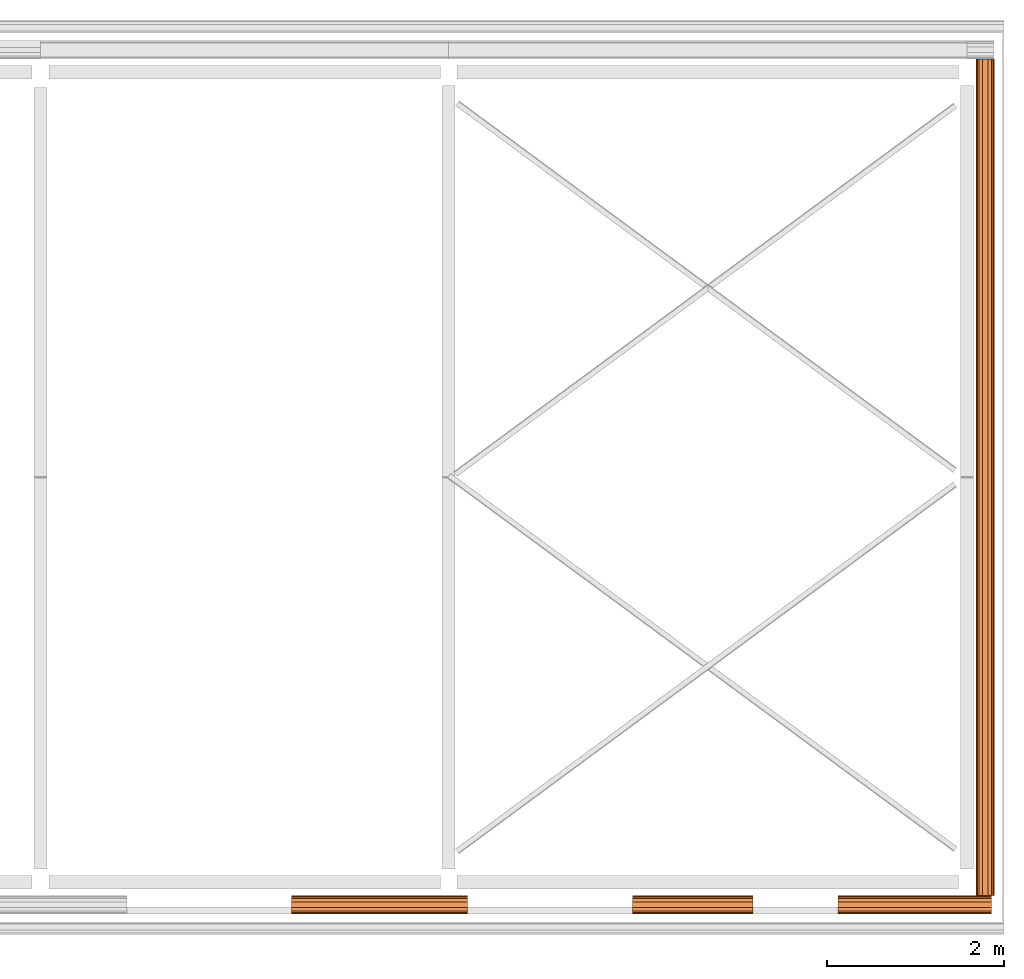
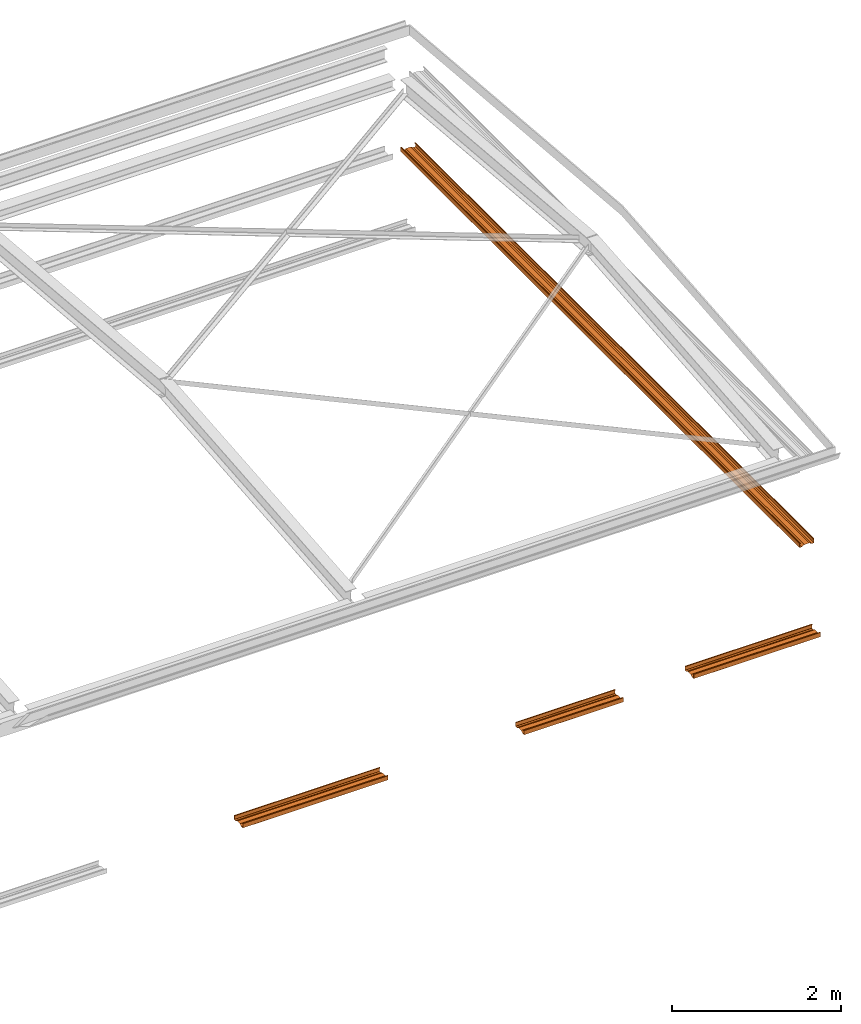
# One storey, part 7 of 8: 4 proxies.
"""IFC2X3 building model written with IfcOpenShell, lengths in millimetres."""

from ifc_helpers import new_model, entity, si_unit, converted_unit, money_unit, direction, frame, origin_with_axes, place, context, subcontext, project, spatial, faceted_brep, material, type_object, element, save


model = new_model("IFC2X3")

# Units and contexts
model_context = context("Model", 3, precision=1e-05, world=origin_with_axes(), true_north=direction((0.0, 1.0)))
body_context = subcontext(model_context, "Body", "Model", "MODEL_VIEW")
ifc_project = project(units=[si_unit("LENGTHUNIT", "METRE", prefix="MILLI"), si_unit("AREAUNIT", "SQUARE_METRE"), si_unit("VOLUMEUNIT", "CUBIC_METRE"), converted_unit("PLANEANGLEUNIT", "DEGREE", entity("IfcPlaneAngleMeasure", 0.0174532925199), si_unit("PLANEANGLEUNIT", "RADIAN"), dimensions=[0, 0, 0, 0, 0, 0, 0]), si_unit("SOLIDANGLEUNIT", "STERADIAN"), money_unit("USD"), converted_unit("TIMEUNIT", "Year", entity("IfcTimeMeasure", 31556926.0), si_unit("TIMEUNIT", "SECOND"), dimensions=[0, 0, 0, 0, 0, 0, 0]), si_unit("MASSUNIT", "GRAM"), si_unit("THERMODYNAMICTEMPERATUREUNIT", "DEGREE_CELSIUS"), si_unit("LUMINOUSINTENSITYUNIT", "LUMEN")], contexts=[model_context])

# Site, building, storey
site_placement = place(None, origin_with_axes())
site = spatial("IfcSite", under=ifc_project, at=site_placement, CompositionType="ELEMENT")
building_placement = place(site_placement, origin_with_axes())
building = spatial("IfcBuilding", under=site, at=building_placement, CompositionType="ELEMENT")
storey_placement = place(building_placement, frame((0.0, 0.0, 74215.0), z_axis=(0.0, 0.0, 1.0), x_axis=(1.0, 0.0, 0.0)))
storey = spatial("IfcBuildingStorey", under=building, at=storey_placement, CompositionType="ELEMENT", Elevation=74215.0)

# Proxies
ifc_material_1 = material(Name="Metal - Steel - Light Gauge")
building_element_proxy_type_1 = type_object("IfcBuildingElementProxyType", Name="M", PredefinedType="USERDEFINED")
proxy_1_placement = place(storey_placement, frame((9330.12953869, -1249.82006319, -2515.0), z_axis=(0.0, 0.0, 1.0), x_axis=(1.0, 0.0, 0.0)))
element("IfcBuildingElementProxy", 1, at=proxy_1_placement, inside=storey, type_object=building_element_proxy_type_1, material=ifc_material_1, Name="Light Gauge-Kingspan Rails:M", ObjectType="M", context=body_context, shape_type="Brep", body=[
    faceted_brep([(-549.0, 70.5, 0.0), (-549.0, 99.3, 0.0), (1440.0, 99.3, 0.0), (1440.0, 70.5, 0.0), (-549.0, 32.5, 20.0), (-549.0, -32.5, 20.0), (-549.0, -70.5, 0.0), (-549.0, -99.3, 0.0), (-549.0, -100.524586984, 0.24358549596), (-549.0, -101.5627417, 0.9372583002), (-549.0, -102.256414504, 1.97541301643), (-549.0, -102.5, 3.2), (-549.0, -102.5, 61.8), (-549.0, -102.256414504, 63.0245869836), (-549.0, -101.5627417, 64.0627416998), (-549.0, -100.524586984, 64.756414504), (-549.0, -99.3, 65.0), (-549.0, -91.7, 65.0), (-549.0, -90.4754130164, 64.756414504), (-549.0, -89.4372583002, 64.0627416998), (-549.0, -88.743585496, 63.0245869836), (-549.0, -88.5, 61.8), (-549.0, -88.5, 53.0), (-549.0, -90.1, 53.0), (-549.0, -90.1, 61.8), (-549.0, -90.221792748, 62.4122934918), (-549.0, -90.5686291501, 62.9313708499), (-549.0, -91.0877065082, 63.278207252), (-549.0, -91.7, 63.4), (-549.0, -99.3, 63.4), (-549.0, -99.9122934918, 63.278207252), (-549.0, -100.43137085, 62.9313708499), (-549.0, -100.778207252, 62.4122934918), (-549.0, -100.9, 61.8), (-549.0, -100.9, 3.2), (-549.0, -100.778207252, 2.58770650822), (-549.0, -100.43137085, 2.0686291501), (-549.0, -99.9122934918, 1.72179274798), (-549.0, -99.3, 1.6), (-549.0, -70.8953456886, 1.6), (-549.0, -32.8953456886, 21.6), (-549.0, 32.8953456886, 21.6), (-549.0, 70.8953456886, 1.6), (-549.0, 99.3, 1.6), (-549.0, 99.9122934918, 1.72179274798), (-549.0, 100.43137085, 2.0686291501), (-549.0, 100.778207252, 2.58770650822), (-549.0, 100.9, 3.2), (-549.0, 100.9, 61.8), (-549.0, 100.778207252, 62.4122934918), (-549.0, 100.43137085, 62.9313708499), (-549.0, 99.9122934918, 63.278207252), (-549.0, 99.3, 63.4), (-549.0, 91.7, 63.4), (-549.0, 91.0877065082, 63.278207252), (-549.0, 90.5686291501, 62.9313708499), (-549.0, 90.221792748, 62.4122934918), (-549.0, 90.1, 61.8), (-549.0, 90.1, 53.0), (-549.0, 88.5, 53.0), (-549.0, 88.5, 61.8), (-549.0, 88.743585496, 63.0245869836), (-549.0, 89.4372583002, 64.0627416998), (-549.0, 90.4754130164, 64.756414504), (-549.0, 91.7, 65.0), (-549.0, 99.3, 65.0), (-549.0, 100.524586984, 64.756414504), (-549.0, 101.5627417, 64.0627416998), (-549.0, 102.256414504, 63.0245869836), (-549.0, 102.5, 61.8), (-549.0, 102.5, 3.2), (-549.0, 102.256414504, 1.97541301643), (-549.0, 101.5627417, 0.9372583002), (-549.0, 100.524586984, 0.24358549596), (1440.0, 100.524586984, 0.24358549596), (1440.0, 101.5627417, 0.9372583002), (1440.0, 102.256414504, 1.97541301643), (1440.0, 102.5, 3.2), (1440.0, 102.5, 61.8), (1440.0, 102.256414504, 63.0245869836), (1440.0, 101.5627417, 64.0627416998), (1440.0, 100.524586984, 64.756414504), (1440.0, 99.3, 65.0), (1440.0, 91.7, 65.0), (1440.0, 90.4754130164, 64.756414504), (1440.0, 89.4372583002, 64.0627416998), (1440.0, 88.743585496, 63.0245869836), (1440.0, 88.5, 61.8), (1440.0, 88.5, 53.0), (1440.0, 90.1, 53.0), (1440.0, 90.1, 61.8), (1440.0, 90.221792748, 62.4122934918), (1440.0, 90.5686291501, 62.9313708499), (1440.0, 91.0877065082, 63.278207252), (1440.0, 91.7, 63.4), (1440.0, 99.3, 63.4), (1440.0, 99.9122934918, 63.278207252), (1440.0, 100.43137085, 62.9313708499), (1440.0, 100.778207252, 62.4122934918), (1440.0, 100.9, 61.8), (1440.0, 100.9, 3.2), (1440.0, 100.778207252, 2.58770650822), (1440.0, 100.43137085, 2.0686291501), (1440.0, 99.9122934918, 1.72179274798), (1440.0, 99.3, 1.6), (1440.0, 70.8953456886, 1.6), (1440.0, 32.8953456886, 21.6), (1440.0, -32.8953456886, 21.6), (1440.0, -70.8953456886, 1.6), (1440.0, -99.3, 1.6), (1440.0, -99.9122934918, 1.72179274798), (1440.0, -100.43137085, 2.0686291501), (1440.0, -100.778207252, 2.58770650822), (1440.0, -100.9, 3.2), (1440.0, -100.9, 61.8), (1440.0, -100.778207252, 62.4122934918), (1440.0, -100.43137085, 62.9313708499), (1440.0, -99.9122934918, 63.278207252), (1440.0, -99.3, 63.4), (1440.0, -91.7, 63.4), (1440.0, -91.0877065082, 63.278207252), (1440.0, -90.5686291501, 62.9313708499), (1440.0, -90.221792748, 62.4122934918), (1440.0, -90.1, 61.8), (1440.0, -90.1, 53.0), (1440.0, -88.5, 53.0), (1440.0, -88.5, 61.8), (1440.0, -88.743585496, 63.0245869836), (1440.0, -89.4372583002, 64.0627416998), (1440.0, -90.4754130164, 64.756414504), (1440.0, -91.7, 65.0), (1440.0, -99.3, 65.0), (1440.0, -100.524586984, 64.756414504), (1440.0, -101.5627417, 64.0627416998), (1440.0, -102.256414504, 63.0245869836), (1440.0, -102.5, 61.8), (1440.0, -102.5, 3.2), (1440.0, -102.256414504, 1.97541301643), (1440.0, -101.5627417, 0.9372583002), (1440.0, -100.524586984, 0.24358549596), (1440.0, -99.3, 0.0), (1440.0, -70.5, 0.0), (1440.0, -32.5, 20.0), (1440.0, 32.5, 20.0)], [[[0, 1, 2, 3]], [[0, 4, 5, 6, 7, 8, 9, 10, 11, 12, 13, 14, 15, 16, 17, 18, 19, 20, 21, 22, 23, 24, 25, 26, 27, 28, 29, 30, 31, 32, 33, 34, 35, 36, 37, 38, 39, 40, 41, 42, 43, 44, 45, 46, 47, 48, 49, 50, 51, 52, 53, 54, 55, 56, 57, 58, 59, 60, 61, 62, 63, 64, 65, 66, 67, 68, 69, 70, 71, 72, 73, 1]], [[1, 73, 74, 2]], [[3, 2, 74, 75, 76, 77, 78, 79, 80, 81, 82, 83, 84, 85, 86, 87, 88, 89, 90, 91, 92, 93, 94, 95, 96, 97, 98, 99, 100, 101, 102, 103, 104, 105, 106, 107, 108, 109, 110, 111, 112, 113, 114, 115, 116, 117, 118, 119, 120, 121, 122, 123, 124, 125, 126, 127, 128, 129, 130, 131, 132, 133, 134, 135, 136, 137, 138, 139, 140, 141, 142, 143]], [[4, 0, 3, 143]], [[5, 4, 143, 142]], [[6, 5, 142, 141]], [[7, 6, 141, 140]], [[8, 7, 140, 139]], [[9, 8, 139, 138]], [[10, 9, 138, 137]], [[11, 10, 137, 136]], [[12, 11, 136, 135]], [[13, 12, 135, 134]], [[14, 13, 134, 133]], [[15, 14, 133, 132]], [[16, 15, 132, 131]], [[17, 16, 131, 130]], [[18, 17, 130, 129]], [[19, 18, 129, 128]], [[20, 19, 128, 127]], [[21, 20, 127, 126]], [[22, 21, 126, 125]], [[23, 22, 125, 124]], [[24, 23, 124, 123]], [[25, 24, 123, 122]], [[26, 25, 122, 121]], [[27, 26, 121, 120]], [[28, 27, 120, 119]], [[29, 28, 119, 118]], [[30, 29, 118, 117]], [[31, 30, 117, 116]], [[32, 31, 116, 115]], [[33, 32, 115, 114]], [[34, 33, 114, 113]], [[35, 34, 113, 112]], [[36, 35, 112, 111]], [[37, 36, 111, 110]], [[38, 37, 110, 109]], [[39, 38, 109, 108]], [[40, 39, 108, 107]], [[41, 40, 107, 106]], [[42, 41, 106, 105]], [[43, 42, 105, 104]], [[44, 43, 104, 103]], [[45, 44, 103, 102]], [[46, 45, 102, 101]], [[47, 46, 101, 100]], [[48, 47, 100, 99]], [[49, 48, 99, 98]], [[50, 49, 98, 97]], [[51, 50, 97, 96]], [[52, 51, 96, 95]], [[53, 52, 95, 94]], [[54, 53, 94, 93]], [[55, 54, 93, 92]], [[56, 55, 92, 91]], [[57, 56, 91, 90]], [[58, 57, 90, 89]], [[59, 58, 89, 88]], [[60, 59, 88, 87]], [[61, 60, 87, 86]], [[62, 61, 86, 85]], [[63, 62, 85, 84]], [[64, 63, 84, 83]], [[65, 64, 83, 82]], [[66, 65, 82, 81]], [[67, 66, 81, 80]], [[68, 67, 80, 79]], [[69, 68, 79, 78]], [[70, 69, 78, 77]], [[71, 70, 77, 76]], [[72, 71, 76, 75]], [[73, 72, 75, 74]]]),
])
ifc_material_2 = material(Name="Metal - Steel 43-275")
building_element_proxy_type_2 = type_object("IfcBuildingElementProxyType", Name="M", PredefinedType="USERDEFINED")
proxy_2_placement = place(storey_placement, frame((16615.5295383, 3647.37929782, -1290.0), z_axis=(0.0, 0.0, 1.0), x_axis=(0.0, -1.0, 0.0)))
element("IfcBuildingElementProxy", 2, at=proxy_2_placement, inside=storey, type_object=building_element_proxy_type_2, material=ifc_material_2, Name="Light Gauge-Kingspan Rails:M", ObjectType="M", context=body_context, shape_type="Brep", body=[
    faceted_brep([(-4654.0, 70.5, 0.0), (-4654.0, 99.3, 0.0), (4795.0, 99.3, 0.0), (4795.0, 70.5, 0.0), (-4654.0, 32.5, 20.0), (-4654.0, -32.5, 20.0), (-4654.0, -70.5, 0.0), (-4654.0, -99.3, 0.0), (-4654.0, -100.524586984, 0.24358549596), (-4654.0, -101.5627417, 0.9372583002), (-4654.0, -102.256414504, 1.97541301643), (-4654.0, -102.5, 3.2), (-4654.0, -102.5, 61.8), (-4654.0, -102.256414504, 63.0245869836), (-4654.0, -101.5627417, 64.0627416998), (-4654.0, -100.524586984, 64.756414504), (-4654.0, -99.3, 65.0), (-4654.0, -91.7, 65.0), (-4654.0, -90.4754130164, 64.756414504), (-4654.0, -89.4372583002, 64.0627416998), (-4654.0, -88.743585496, 63.0245869836), (-4654.0, -88.5, 61.8), (-4654.0, -88.5, 53.0), (-4654.0, -90.1, 53.0), (-4654.0, -90.1, 61.8), (-4654.0, -90.221792748, 62.4122934918), (-4654.0, -90.5686291501, 62.9313708499), (-4654.0, -91.0877065082, 63.278207252), (-4654.0, -91.7, 63.4), (-4654.0, -99.3, 63.4), (-4654.0, -99.9122934918, 63.278207252), (-4654.0, -100.43137085, 62.9313708499), (-4654.0, -100.778207252, 62.4122934918), (-4654.0, -100.9, 61.8), (-4654.0, -100.9, 3.2), (-4654.0, -100.778207252, 2.58770650822), (-4654.0, -100.43137085, 2.0686291501), (-4654.0, -99.9122934918, 1.72179274798), (-4654.0, -99.3, 1.6), (-4654.0, -70.8953456886, 1.6), (-4654.0, -32.8953456886, 21.6), (-4654.0, 32.8953456886, 21.6), (-4654.0, 70.8953456886, 1.6), (-4654.0, 99.3, 1.6), (-4654.0, 99.9122934918, 1.72179274798), (-4654.0, 100.43137085, 2.0686291501), (-4654.0, 100.778207252, 2.58770650822), (-4654.0, 100.9, 3.2), (-4654.0, 100.9, 61.8), (-4654.0, 100.778207252, 62.4122934918), (-4654.0, 100.43137085, 62.9313708499), (-4654.0, 99.9122934918, 63.278207252), (-4654.0, 99.3, 63.4), (-4654.0, 91.7, 63.4), (-4654.0, 91.0877065082, 63.278207252), (-4654.0, 90.5686291501, 62.9313708499), (-4654.0, 90.221792748, 62.4122934918), (-4654.0, 90.1, 61.8), (-4654.0, 90.1, 53.0), (-4654.0, 88.5, 53.0), (-4654.0, 88.5, 61.8), (-4654.0, 88.743585496, 63.0245869836), (-4654.0, 89.4372583002, 64.0627416998), (-4654.0, 90.4754130164, 64.756414504), (-4654.0, 91.7, 65.0), (-4654.0, 99.3, 65.0), (-4654.0, 100.524586984, 64.756414504), (-4654.0, 101.5627417, 64.0627416998), (-4654.0, 102.256414504, 63.0245869836), (-4654.0, 102.5, 61.8), (-4654.0, 102.5, 3.2), (-4654.0, 102.256414504, 1.97541301643), (-4654.0, 101.5627417, 0.9372583002), (-4654.0, 100.524586984, 0.24358549596), (4795.0, 100.524586984, 0.24358549596), (4795.0, 101.5627417, 0.9372583002), (4795.0, 102.256414504, 1.97541301643), (4795.0, 102.5, 3.2), (4795.0, 102.5, 61.8), (4795.0, 102.256414504, 63.0245869836), (4795.0, 101.5627417, 64.0627416998), (4795.0, 100.524586984, 64.756414504), (4795.0, 99.3, 65.0), (4795.0, 91.7, 65.0), (4795.0, 90.4754130164, 64.756414504), (4795.0, 89.4372583002, 64.0627416998), (4795.0, 88.743585496, 63.0245869836), (4795.0, 88.5, 61.8), (4795.0, 88.5, 53.0), (4795.0, 90.1, 53.0), (4795.0, 90.1, 61.8), (4795.0, 90.221792748, 62.4122934918), (4795.0, 90.5686291501, 62.9313708499), (4795.0, 91.0877065082, 63.278207252), (4795.0, 91.7, 63.4), (4795.0, 99.3, 63.4), (4795.0, 99.9122934918, 63.278207252), (4795.0, 100.43137085, 62.9313708499), (4795.0, 100.778207252, 62.4122934918), (4795.0, 100.9, 61.8), (4795.0, 100.9, 3.2), (4795.0, 100.778207252, 2.58770650822), (4795.0, 100.43137085, 2.0686291501), (4795.0, 99.9122934918, 1.72179274798), (4795.0, 99.3, 1.6), (4795.0, 70.8953456886, 1.6), (4795.0, 32.8953456886, 21.6), (4795.0, -32.8953456886, 21.6), (4795.0, -70.8953456886, 1.6), (4795.0, -99.3, 1.6), (4795.0, -99.9122934918, 1.72179274798), (4795.0, -100.43137085, 2.0686291501), (4795.0, -100.778207252, 2.58770650822), (4795.0, -100.9, 3.2), (4795.0, -100.9, 61.8), (4795.0, -100.778207252, 62.4122934918), (4795.0, -100.43137085, 62.9313708499), (4795.0, -99.9122934918, 63.278207252), (4795.0, -99.3, 63.4), (4795.0, -91.7, 63.4), (4795.0, -91.0877065082, 63.278207252), (4795.0, -90.5686291501, 62.9313708499), (4795.0, -90.221792748, 62.4122934918), (4795.0, -90.1, 61.8), (4795.0, -90.1, 53.0), (4795.0, -88.5, 53.0), (4795.0, -88.5, 61.8), (4795.0, -88.743585496, 63.0245869836), (4795.0, -89.4372583002, 64.0627416998), (4795.0, -90.4754130164, 64.756414504), (4795.0, -91.7, 65.0), (4795.0, -99.3, 65.0), (4795.0, -100.524586984, 64.756414504), (4795.0, -101.5627417, 64.0627416998), (4795.0, -102.256414504, 63.0245869836), (4795.0, -102.5, 61.8), (4795.0, -102.5, 3.2), (4795.0, -102.256414504, 1.97541301643), (4795.0, -101.5627417, 0.9372583002), (4795.0, -100.524586984, 0.24358549596), (4795.0, -99.3, 0.0), (4795.0, -70.5, 0.0), (4795.0, -32.5, 20.0), (4795.0, 32.5, 20.0)], [[[0, 1, 2, 3]], [[0, 4, 5, 6, 7, 8, 9, 10, 11, 12, 13, 14, 15, 16, 17, 18, 19, 20, 21, 22, 23, 24, 25, 26, 27, 28, 29, 30, 31, 32, 33, 34, 35, 36, 37, 38, 39, 40, 41, 42, 43, 44, 45, 46, 47, 48, 49, 50, 51, 52, 53, 54, 55, 56, 57, 58, 59, 60, 61, 62, 63, 64, 65, 66, 67, 68, 69, 70, 71, 72, 73, 1]], [[1, 73, 74, 2]], [[3, 2, 74, 75, 76, 77, 78, 79, 80, 81, 82, 83, 84, 85, 86, 87, 88, 89, 90, 91, 92, 93, 94, 95, 96, 97, 98, 99, 100, 101, 102, 103, 104, 105, 106, 107, 108, 109, 110, 111, 112, 113, 114, 115, 116, 117, 118, 119, 120, 121, 122, 123, 124, 125, 126, 127, 128, 129, 130, 131, 132, 133, 134, 135, 136, 137, 138, 139, 140, 141, 142, 143]], [[4, 0, 3, 143]], [[5, 4, 143, 142]], [[6, 5, 142, 141]], [[7, 6, 141, 140]], [[8, 7, 140, 139]], [[9, 8, 139, 138]], [[10, 9, 138, 137]], [[11, 10, 137, 136]], [[12, 11, 136, 135]], [[13, 12, 135, 134]], [[14, 13, 134, 133]], [[15, 14, 133, 132]], [[16, 15, 132, 131]], [[17, 16, 131, 130]], [[18, 17, 130, 129]], [[19, 18, 129, 128]], [[20, 19, 128, 127]], [[21, 20, 127, 126]], [[22, 21, 126, 125]], [[23, 22, 125, 124]], [[24, 23, 124, 123]], [[25, 24, 123, 122]], [[26, 25, 122, 121]], [[27, 26, 121, 120]], [[28, 27, 120, 119]], [[29, 28, 119, 118]], [[30, 29, 118, 117]], [[31, 30, 117, 116]], [[32, 31, 116, 115]], [[33, 32, 115, 114]], [[34, 33, 114, 113]], [[35, 34, 113, 112]], [[36, 35, 112, 111]], [[37, 36, 111, 110]], [[38, 37, 110, 109]], [[39, 38, 109, 108]], [[40, 39, 108, 107]], [[41, 40, 107, 106]], [[42, 41, 106, 105]], [[43, 42, 105, 104]], [[44, 43, 104, 103]], [[45, 44, 103, 102]], [[46, 45, 102, 101]], [[47, 46, 101, 100]], [[48, 47, 100, 99]], [[49, 48, 99, 98]], [[50, 49, 98, 97]], [[51, 50, 97, 96]], [[52, 51, 96, 95]], [[53, 52, 95, 94]], [[54, 53, 94, 93]], [[55, 54, 93, 92]], [[56, 55, 92, 91]], [[57, 56, 91, 90]], [[58, 57, 90, 89]], [[59, 58, 89, 88]], [[60, 59, 88, 87]], [[61, 60, 87, 86]], [[62, 61, 86, 85]], [[63, 62, 85, 84]], [[64, 63, 84, 83]], [[65, 64, 83, 82]], [[66, 65, 82, 81]], [[67, 66, 81, 80]], [[68, 67, 80, 79]], [[69, 68, 79, 78]], [[70, 69, 78, 77]], [[71, 70, 77, 76]], [[72, 71, 76, 75]], [[73, 72, 75, 74]]]),
])
building_element_proxy_type_3 = type_object("IfcBuildingElementProxyType", Name="M", PredefinedType="USERDEFINED")
proxy_3_placement = place(storey_placement, frame((15572.6295387, -1249.82006319, -2515.0), z_axis=(0.0, 0.0, 1.0), x_axis=(1.0, 0.0, 0.0)))
element("IfcBuildingElementProxy", 3, at=proxy_3_placement, inside=storey, type_object=building_element_proxy_type_3, material=ifc_material_1, Name="Light Gauge-Kingspan Rails:M", ObjectType="M", context=body_context, shape_type="Brep", body=[
    faceted_brep([(-621.5, 70.5, 0.0), (-621.5, 99.3, 0.0), (1112.09993903, 99.3, 0.0), (1112.09993903, 70.5, 0.0), (-621.5, 32.5, 20.0), (-621.5, -32.5, 20.0), (-621.5, -70.5, 0.0), (-621.5, -99.3, 0.0), (-621.5, -100.524586984, 0.24358549596), (-621.5, -101.5627417, 0.9372583002), (-621.5, -102.256414504, 1.97541301643), (-621.5, -102.5, 3.2), (-621.5, -102.5, 61.8), (-621.5, -102.256414504, 63.0245869836), (-621.5, -101.5627417, 64.0627416998), (-621.5, -100.524586984, 64.756414504), (-621.5, -99.3, 65.0), (-621.5, -91.7, 65.0), (-621.5, -90.4754130164, 64.756414504), (-621.5, -89.4372583002, 64.0627416998), (-621.5, -88.743585496, 63.0245869836), (-621.5, -88.5, 61.8), (-621.5, -88.5, 53.0), (-621.5, -90.1, 53.0), (-621.5, -90.1, 61.8), (-621.5, -90.221792748, 62.4122934918), (-621.5, -90.5686291501, 62.9313708499), (-621.5, -91.0877065082, 63.278207252), (-621.5, -91.7, 63.4), (-621.5, -99.3, 63.4), (-621.5, -99.9122934918, 63.278207252), (-621.5, -100.43137085, 62.9313708499), (-621.5, -100.778207252, 62.4122934918), (-621.5, -100.9, 61.8), (-621.5, -100.9, 3.2), (-621.5, -100.778207252, 2.58770650822), (-621.5, -100.43137085, 2.0686291501), (-621.5, -99.9122934918, 1.72179274798), (-621.5, -99.3, 1.6), (-621.5, -70.8953456886, 1.6), (-621.5, -32.8953456886, 21.6), (-621.5, 32.8953456886, 21.6), (-621.5, 70.8953456886, 1.6), (-621.5, 99.3, 1.6), (-621.5, 99.9122934918, 1.72179274798), (-621.5, 100.43137085, 2.0686291501), (-621.5, 100.778207252, 2.58770650822), (-621.5, 100.9, 3.2), (-621.5, 100.9, 61.8), (-621.5, 100.778207252, 62.4122934918), (-621.5, 100.43137085, 62.9313708499), (-621.5, 99.9122934918, 63.278207252), (-621.5, 99.3, 63.4), (-621.5, 91.7, 63.4), (-621.5, 91.0877065082, 63.278207252), (-621.5, 90.5686291501, 62.9313708499), (-621.5, 90.221792748, 62.4122934918), (-621.5, 90.1, 61.8), (-621.5, 90.1, 53.0), (-621.5, 88.5, 53.0), (-621.5, 88.5, 61.8), (-621.5, 88.743585496, 63.0245869836), (-621.5, 89.4372583002, 64.0627416998), (-621.5, 90.4754130164, 64.756414504), (-621.5, 91.7, 65.0), (-621.5, 99.3, 65.0), (-621.5, 100.524586984, 64.756414504), (-621.5, 101.5627417, 64.0627416998), (-621.5, 102.256414504, 63.0245869836), (-621.5, 102.5, 61.8), (-621.5, 102.5, 3.2), (-621.5, 102.256414504, 1.97541301643), (-621.5, 101.5627417, 0.9372583002), (-621.5, 100.524586984, 0.24358549596), (1112.09993903, 100.524586984, 0.24358549596), (1112.09993903, 101.5627417, 0.9372583002), (1112.09993903, 102.256414504, 1.97541301643), (1112.09993903, 102.5, 3.2), (1112.09993903, 102.5, 61.8), (1112.09993903, 102.256414504, 63.0245869836), (1112.09993903, 101.5627417, 64.0627416998), (1112.09993903, 100.524586984, 64.756414504), (1112.09993903, 99.3, 65.0), (1112.09993903, 91.7, 65.0), (1112.09993903, 90.4754130164, 64.756414504), (1112.09993903, 89.4372583002, 64.0627416998), (1112.09993903, 88.743585496, 63.0245869836), (1112.09993903, 88.5, 61.8), (1112.09993903, 88.5, 53.0), (1112.09993903, 90.1, 53.0), (1112.09993903, 90.1, 61.8), (1112.09993903, 90.221792748, 62.4122934918), (1112.09993903, 90.5686291501, 62.9313708499), (1112.09993903, 91.0877065082, 63.278207252), (1112.09993903, 91.7, 63.4), (1112.09993903, 99.3, 63.4), (1112.09993903, 99.9122934918, 63.278207252), (1112.09993903, 100.43137085, 62.9313708499), (1112.09993903, 100.778207252, 62.4122934918), (1112.09993903, 100.9, 61.8), (1112.09993903, 100.9, 3.2), (1112.09993903, 100.778207252, 2.58770650822), (1112.09993903, 100.43137085, 2.0686291501), (1112.09993903, 99.9122934918, 1.72179274798), (1112.09993903, 99.3, 1.6), (1112.09993903, 70.8953456886, 1.6), (1112.09993903, 32.8953456886, 21.6), (1112.09993903, -32.8953456886, 21.6), (1112.09993903, -70.8953456886, 1.6), (1112.09993903, -99.3, 1.6), (1112.09993903, -99.9122934918, 1.72179274798), (1112.09993903, -100.43137085, 2.0686291501), (1112.09993903, -100.778207252, 2.58770650822), (1112.09993903, -100.9, 3.2), (1112.09993903, -100.9, 61.8), (1112.09993903, -100.778207252, 62.4122934918), (1112.09993903, -100.43137085, 62.9313708499), (1112.09993903, -99.9122934918, 63.278207252), (1112.09993903, -99.3, 63.4), (1112.09993903, -91.7, 63.4), (1112.09993903, -91.0877065082, 63.278207252), (1112.09993903, -90.5686291501, 62.9313708499), (1112.09993903, -90.221792748, 62.4122934918), (1112.09993903, -90.1, 61.8), (1112.09993903, -90.1, 53.0), (1112.09993903, -88.5, 53.0), (1112.09993903, -88.5, 61.8), (1112.09993903, -88.743585496, 63.0245869836), (1112.09993903, -89.4372583002, 64.0627416998), (1112.09993903, -90.4754130164, 64.756414504), (1112.09993903, -91.7, 65.0), (1112.09993903, -99.3, 65.0), (1112.09993903, -100.524586984, 64.756414504), (1112.09993903, -101.5627417, 64.0627416998), (1112.09993903, -102.256414504, 63.0245869836), (1112.09993903, -102.5, 61.8), (1112.09993903, -102.5, 3.2), (1112.09993903, -102.256414504, 1.97541301643), (1112.09993903, -101.5627417, 0.9372583002), (1112.09993903, -100.524586984, 0.24358549596), (1112.09993903, -99.3, 0.0), (1112.09993903, -70.5, 0.0), (1112.09993903, -32.5, 20.0), (1112.09993903, 32.5, 20.0)], [[[0, 1, 2, 3]], [[0, 4, 5, 6, 7, 8, 9, 10, 11, 12, 13, 14, 15, 16, 17, 18, 19, 20, 21, 22, 23, 24, 25, 26, 27, 28, 29, 30, 31, 32, 33, 34, 35, 36, 37, 38, 39, 40, 41, 42, 43, 44, 45, 46, 47, 48, 49, 50, 51, 52, 53, 54, 55, 56, 57, 58, 59, 60, 61, 62, 63, 64, 65, 66, 67, 68, 69, 70, 71, 72, 73, 1]], [[1, 73, 74, 2]], [[3, 2, 74, 75, 76, 77, 78, 79, 80, 81, 82, 83, 84, 85, 86, 87, 88, 89, 90, 91, 92, 93, 94, 95, 96, 97, 98, 99, 100, 101, 102, 103, 104, 105, 106, 107, 108, 109, 110, 111, 112, 113, 114, 115, 116, 117, 118, 119, 120, 121, 122, 123, 124, 125, 126, 127, 128, 129, 130, 131, 132, 133, 134, 135, 136, 137, 138, 139, 140, 141, 142, 143]], [[4, 0, 3, 143]], [[5, 4, 143, 142]], [[6, 5, 142, 141]], [[7, 6, 141, 140]], [[8, 7, 140, 139]], [[9, 8, 139, 138]], [[10, 9, 138, 137]], [[11, 10, 137, 136]], [[12, 11, 136, 135]], [[13, 12, 135, 134]], [[14, 13, 134, 133]], [[15, 14, 133, 132]], [[16, 15, 132, 131]], [[17, 16, 131, 130]], [[18, 17, 130, 129]], [[19, 18, 129, 128]], [[20, 19, 128, 127]], [[21, 20, 127, 126]], [[22, 21, 126, 125]], [[23, 22, 125, 124]], [[24, 23, 124, 123]], [[25, 24, 123, 122]], [[26, 25, 122, 121]], [[27, 26, 121, 120]], [[28, 27, 120, 119]], [[29, 28, 119, 118]], [[30, 29, 118, 117]], [[31, 30, 117, 116]], [[32, 31, 116, 115]], [[33, 32, 115, 114]], [[34, 33, 114, 113]], [[35, 34, 113, 112]], [[36, 35, 112, 111]], [[37, 36, 111, 110]], [[38, 37, 110, 109]], [[39, 38, 109, 108]], [[40, 39, 108, 107]], [[41, 40, 107, 106]], [[42, 41, 106, 105]], [[43, 42, 105, 104]], [[44, 43, 104, 103]], [[45, 44, 103, 102]], [[46, 45, 102, 101]], [[47, 46, 101, 100]], [[48, 47, 100, 99]], [[49, 48, 99, 98]], [[50, 49, 98, 97]], [[51, 50, 97, 96]], [[52, 51, 96, 95]], [[53, 52, 95, 94]], [[54, 53, 94, 93]], [[55, 54, 93, 92]], [[56, 55, 92, 91]], [[57, 56, 91, 90]], [[58, 57, 90, 89]], [[59, 58, 89, 88]], [[60, 59, 88, 87]], [[61, 60, 87, 86]], [[62, 61, 86, 85]], [[63, 62, 85, 84]], [[64, 63, 84, 83]], [[65, 64, 83, 82]], [[66, 65, 82, 81]], [[67, 66, 81, 80]], [[68, 67, 80, 79]], [[69, 68, 79, 78]], [[70, 69, 78, 77]], [[71, 70, 77, 76]], [[72, 71, 76, 75]], [[73, 72, 75, 74]]]),
])
building_element_proxy_type_4 = type_object("IfcBuildingElementProxyType", Name="M", PredefinedType="USERDEFINED")
proxy_4_placement = place(storey_placement, frame((12631.1295387, -1353.91533543, -2516.59527224), z_axis=(0.0, 0.0, 1.0), x_axis=(1.0, 0.0, 0.0)))
element("IfcBuildingElementProxy", 4, at=proxy_4_placement, inside=storey, type_object=building_element_proxy_type_4, material=ifc_material_1, Name="Light Gauge-Kingspan Rails:M", ObjectType="M", context=body_context, shape_type="Brep", body=[
    faceted_brep([(0.0, 174.595272236, 1.59527223592), (0.0, 203.395272236, 1.59527223592), (1359.64957315, 203.395272236, 1.59527223592), (1359.64957315, 174.595272236, 1.59527223592), (0.0, 136.595272236, 21.5952722359), (0.0, 71.5952722359, 21.5952722359), (0.0, 33.5952722359, 1.59527223592), (0.0, 4.79527223592, 1.59527223592), (0.0, 3.57068525235, 1.83885773188), (0.0, 2.53253053612, 2.53253053612), (0.0, 1.83885773188, 3.57068525235), (0.0, 1.59527223592, 4.79527223592), (0.0, 1.59527223592, 63.3952722359), (0.0, 1.83885773188, 64.6198592195), (0.0, 2.53253053612, 65.6580139357), (0.0, 3.57068525235, 66.35168674), (0.0, 4.79527223592, 66.5952722359), (0.0, 12.3952722359, 66.5952722359), (0.0, 13.6198592195, 66.35168674), (0.0, 14.6580139357, 65.6580139357), (0.0, 15.35168674, 64.6198592195), (0.0, 15.5952722359, 63.3952722359), (0.0, 15.5952722359, 54.5952722359), (0.0, 13.9952722359, 54.5952722359), (0.0, 13.9952722359, 63.3952722359), (0.0, 13.8734794879, 64.0075657277), (0.0, 13.5266430858, 64.5266430858), (0.0, 13.0075657277, 64.8734794879), (0.0, 12.3952722359, 64.9952722359), (0.0, 4.79527223592, 64.9952722359), (0.0, 4.18297874414, 64.8734794879), (0.0, 3.66390138602, 64.5266430858), (0.0, 3.3170649839, 64.0075657277), (0.0, 3.19527223592, 63.3952722359), (0.0, 3.19527223592, 4.79527223592), (0.0, 3.3170649839, 4.18297874414), (0.0, 3.66390138602, 3.66390138602), (0.0, 4.18297874414, 3.3170649839), (0.0, 4.79527223592, 3.19527223592), (0.0, 33.1999265474, 3.19527223592), (0.0, 71.1999265474, 23.1952722359), (0.0, 136.990617924, 23.1952722359), (0.0, 174.990617924, 3.19527223592), (0.0, 203.395272236, 3.19527223592), (0.0, 204.007565728, 3.3170649839), (0.0, 204.526643086, 3.66390138602), (0.0, 204.873479488, 4.18297874414), (0.0, 204.995272236, 4.79527223592), (0.0, 204.995272236, 63.3952722359), (0.0, 204.873479488, 64.0075657277), (0.0, 204.526643086, 64.5266430858), (0.0, 204.007565728, 64.8734794879), (0.0, 203.395272236, 64.9952722359), (0.0, 195.795272236, 64.9952722359), (0.0, 195.182978744, 64.8734794879), (0.0, 194.663901386, 64.5266430858), (0.0, 194.317064984, 64.0075657277), (0.0, 194.195272236, 63.3952722359), (0.0, 194.195272236, 54.5952722359), (0.0, 192.595272236, 54.5952722359), (0.0, 192.595272236, 63.3952722359), (0.0, 192.838857732, 64.6198592195), (0.0, 193.532530536, 65.6580139357), (0.0, 194.570685252, 66.35168674), (0.0, 195.795272236, 66.5952722359), (0.0, 203.395272236, 66.5952722359), (0.0, 204.619859219, 66.35168674), (0.0, 205.658013936, 65.6580139357), (0.0, 206.35168674, 64.6198592195), (0.0, 206.595272236, 63.3952722359), (0.0, 206.595272236, 4.79527223592), (0.0, 206.35168674, 3.57068525235), (0.0, 205.658013936, 2.53253053612), (0.0, 204.619859219, 1.83885773188), (1359.64957315, 204.619859219, 1.83885773188), (1359.64957315, 205.658013936, 2.53253053612), (1359.64957315, 206.35168674, 3.57068525235), (1359.64957315, 206.595272236, 4.79527223592), (1359.64957315, 206.595272236, 63.3952722359), (1359.64957315, 206.35168674, 64.6198592195), (1359.64957315, 205.658013936, 65.6580139357), (1359.64957315, 204.619859219, 66.35168674), (1359.64957315, 203.395272236, 66.5952722359), (1359.64957315, 195.795272236, 66.5952722359), (1359.64957315, 194.570685252, 66.35168674), (1359.64957315, 193.532530536, 65.6580139357), (1359.64957315, 192.838857732, 64.6198592195), (1359.64957315, 192.595272236, 63.3952722359), (1359.64957315, 192.595272236, 54.5952722359), (1359.64957315, 194.195272236, 54.5952722359), (1359.64957315, 194.195272236, 63.3952722359), (1359.64957315, 194.317064984, 64.0075657277), (1359.64957315, 194.663901386, 64.5266430858), (1359.64957315, 195.182978744, 64.8734794879), (1359.64957315, 195.795272236, 64.9952722359), (1359.64957315, 203.395272236, 64.9952722359), (1359.64957315, 204.007565728, 64.8734794879), (1359.64957315, 204.526643086, 64.5266430858), (1359.64957315, 204.873479488, 64.0075657277), (1359.64957315, 204.995272236, 63.3952722359), (1359.64957315, 204.995272236, 4.79527223592), (1359.64957315, 204.873479488, 4.18297874414), (1359.64957315, 204.526643086, 3.66390138602), (1359.64957315, 204.007565728, 3.3170649839), (1359.64957315, 203.395272236, 3.19527223592), (1359.64957315, 174.990617924, 3.19527223592), (1359.64957315, 136.990617924, 23.1952722359), (1359.64957315, 71.1999265474, 23.1952722359), (1359.64957315, 33.1999265474, 3.19527223592), (1359.64957315, 4.79527223592, 3.19527223592), (1359.64957315, 4.18297874414, 3.3170649839), (1359.64957315, 3.66390138602, 3.66390138602), (1359.64957315, 3.3170649839, 4.18297874414), (1359.64957315, 3.19527223592, 4.79527223592), (1359.64957315, 3.19527223592, 63.3952722359), (1359.64957315, 3.3170649839, 64.0075657277), (1359.64957315, 3.66390138602, 64.5266430858), (1359.64957315, 4.18297874414, 64.8734794879), (1359.64957315, 4.79527223592, 64.9952722359), (1359.64957315, 12.3952722359, 64.9952722359), (1359.64957315, 13.0075657277, 64.8734794879), (1359.64957315, 13.5266430858, 64.5266430858), (1359.64957315, 13.8734794879, 64.0075657277), (1359.64957315, 13.9952722359, 63.3952722359), (1359.64957315, 13.9952722359, 54.5952722359), (1359.64957315, 15.5952722359, 54.5952722359), (1359.64957315, 15.5952722359, 63.3952722359), (1359.64957315, 15.35168674, 64.6198592195), (1359.64957315, 14.6580139357, 65.6580139357), (1359.64957315, 13.6198592195, 66.35168674), (1359.64957315, 12.3952722359, 66.5952722359), (1359.64957315, 4.79527223592, 66.5952722359), (1359.64957315, 3.57068525235, 66.35168674), (1359.64957315, 2.53253053612, 65.6580139357), (1359.64957315, 1.83885773188, 64.6198592195), (1359.64957315, 1.59527223592, 63.3952722359), (1359.64957315, 1.59527223592, 4.79527223592), (1359.64957315, 1.83885773188, 3.57068525235), (1359.64957315, 2.53253053612, 2.53253053612), (1359.64957315, 3.57068525235, 1.83885773188), (1359.64957315, 4.79527223592, 1.59527223592), (1359.64957315, 33.5952722359, 1.59527223592), (1359.64957315, 71.5952722359, 21.5952722359), (1359.64957315, 136.595272236, 21.5952722359)], [[[0, 1, 2, 3]], [[0, 4, 5, 6, 7, 8, 9, 10, 11, 12, 13, 14, 15, 16, 17, 18, 19, 20, 21, 22, 23, 24, 25, 26, 27, 28, 29, 30, 31, 32, 33, 34, 35, 36, 37, 38, 39, 40, 41, 42, 43, 44, 45, 46, 47, 48, 49, 50, 51, 52, 53, 54, 55, 56, 57, 58, 59, 60, 61, 62, 63, 64, 65, 66, 67, 68, 69, 70, 71, 72, 73, 1]], [[1, 73, 74, 2]], [[3, 2, 74, 75, 76, 77, 78, 79, 80, 81, 82, 83, 84, 85, 86, 87, 88, 89, 90, 91, 92, 93, 94, 95, 96, 97, 98, 99, 100, 101, 102, 103, 104, 105, 106, 107, 108, 109, 110, 111, 112, 113, 114, 115, 116, 117, 118, 119, 120, 121, 122, 123, 124, 125, 126, 127, 128, 129, 130, 131, 132, 133, 134, 135, 136, 137, 138, 139, 140, 141, 142, 143]], [[4, 0, 3, 143]], [[5, 4, 143, 142]], [[6, 5, 142, 141]], [[7, 6, 141, 140]], [[8, 7, 140, 139]], [[9, 8, 139, 138]], [[10, 9, 138, 137]], [[11, 10, 137, 136]], [[12, 11, 136, 135]], [[13, 12, 135, 134]], [[14, 13, 134, 133]], [[15, 14, 133, 132]], [[16, 15, 132, 131]], [[17, 16, 131, 130]], [[18, 17, 130, 129]], [[19, 18, 129, 128]], [[20, 19, 128, 127]], [[21, 20, 127, 126]], [[22, 21, 126, 125]], [[23, 22, 125, 124]], [[24, 23, 124, 123]], [[25, 24, 123, 122]], [[26, 25, 122, 121]], [[27, 26, 121, 120]], [[28, 27, 120, 119]], [[29, 28, 119, 118]], [[30, 29, 118, 117]], [[31, 30, 117, 116]], [[32, 31, 116, 115]], [[33, 32, 115, 114]], [[34, 33, 114, 113]], [[35, 34, 113, 112]], [[36, 35, 112, 111]], [[37, 36, 111, 110]], [[38, 37, 110, 109]], [[39, 38, 109, 108]], [[40, 39, 108, 107]], [[41, 40, 107, 106]], [[42, 41, 106, 105]], [[43, 42, 105, 104]], [[44, 43, 104, 103]], [[45, 44, 103, 102]], [[46, 45, 102, 101]], [[47, 46, 101, 100]], [[48, 47, 100, 99]], [[49, 48, 99, 98]], [[50, 49, 98, 97]], [[51, 50, 97, 96]], [[52, 51, 96, 95]], [[53, 52, 95, 94]], [[54, 53, 94, 93]], [[55, 54, 93, 92]], [[56, 55, 92, 91]], [[57, 56, 91, 90]], [[58, 57, 90, 89]], [[59, 58, 89, 88]], [[60, 59, 88, 87]], [[61, 60, 87, 86]], [[62, 61, 86, 85]], [[63, 62, 85, 84]], [[64, 63, 84, 83]], [[65, 64, 83, 82]], [[66, 65, 82, 81]], [[67, 66, 81, 80]], [[68, 67, 80, 79]], [[69, 68, 79, 78]], [[70, 69, 78, 77]], [[71, 70, 77, 76]], [[72, 71, 76, 75]], [[73, 72, 75, 74]]]),
])

save(model, "model.ifc")
